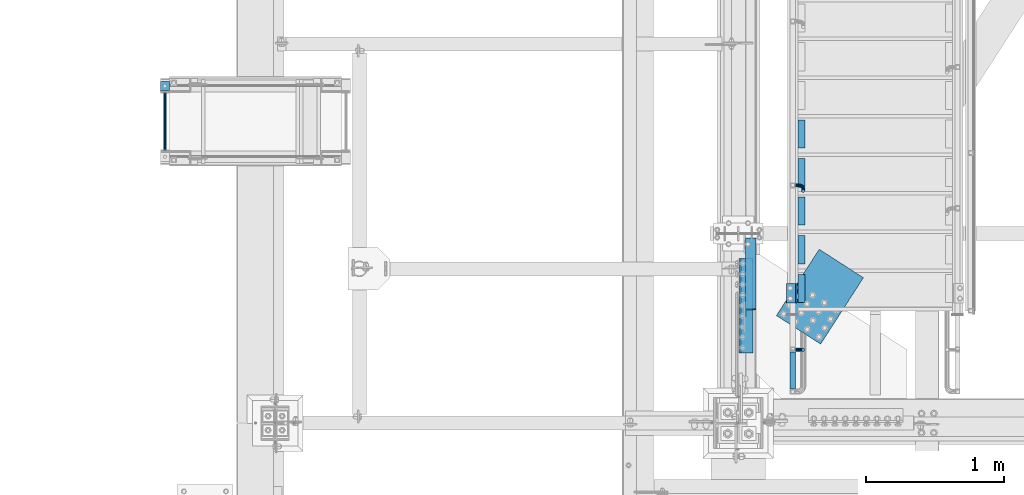
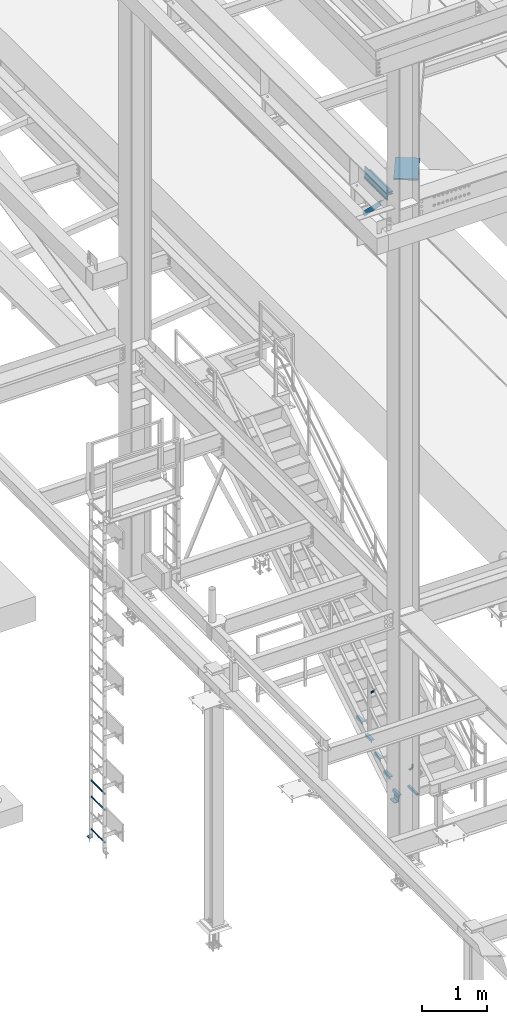
# One storey, part 2014 of 3843: 16 beams, 1 member, 6 elements without a shape of their own.
"""IFC2X3 building model written with IfcOpenShell, lengths in millimetres."""

from ifc_helpers import new_model, si_unit, frame, origin_with_axes, place, context, subcontext, project, spatial, faceted_brep, material, type_object, element, aggregate, save


model = new_model("IFC2X3")

# Units and contexts
model_context = context("Model", 3, precision=1e-05, world=origin_with_axes())
body_context = subcontext(model_context, "Body", "Model", "MODEL_VIEW")
ifc_project = project(units=[si_unit("LENGTHUNIT", "METRE", prefix="MILLI"), si_unit("AREAUNIT", "SQUARE_METRE"), si_unit("VOLUMEUNIT", "CUBIC_METRE"), si_unit("MASSUNIT", "GRAM", prefix="KILO"), si_unit("TIMEUNIT", "SECOND"), si_unit("PLANEANGLEUNIT", "RADIAN"), si_unit("SOLIDANGLEUNIT", "STERADIAN"), si_unit("THERMODYNAMICTEMPERATUREUNIT", "DEGREE_CELSIUS"), si_unit("LUMINOUSINTENSITYUNIT", "LUMEN")], contexts=[model_context])

# Site, building, storey
site_placement = place(None, origin_with_axes())
site = spatial("IfcSite", under=ifc_project, at=site_placement, CompositionType="ELEMENT")
building_placement = place(site_placement, origin_with_axes())
building = spatial("IfcBuilding", under=site, at=building_placement, Name="Undefined", CompositionType="ELEMENT")
storey_placement = place(building_placement, origin_with_axes())
storey = spatial("IfcBuildingStorey", under=building, at=storey_placement, Name="Undefined", CompositionType="ELEMENT", Elevation=0.0)

# Assembly, beam
assembly_1_placement = place(storey_placement, origin_with_axes())
assembly_1 = element("IfcElementAssembly", 1, at=assembly_1_placement, inside=storey, Name="LADDER", AssemblyPlace="NOTDEFINED", PredefinedType="RIGID_FRAME")
ifc_material_1 = material(Name="STEEL/A572-50")
beam_type_1 = type_object("IfcBeamType", Name="L3X3X3/8", PredefinedType="NOTDEFINED")
beam_1_placement = place(assembly_1_placement, frame((32394.0233459473, 28051.1249999999, 30518.1), z_axis=(0.0, 1.0, 0.0), x_axis=(1.0, 0.0, 0.0)))
beam_1 = element("IfcBeam", 2, at=beam_1_placement, type_object=beam_type_1, material=ifc_material_1, Name="ANGLE", ObjectType="L3X3X3/8", context=body_context, shape_type="Brep", body=[
    faceted_brep([(0.0, 38.0999999999985, -38.0999999999985), (0.0, 38.0999999999985, 38.0999999999985), (63.5, 38.0999999999985, 38.0999999999985), (63.5, 38.0999999999985, -38.0999999999985), (0.0, 28.5750000000007, 38.0999999999985), (63.5, 28.5750000000007, 38.0999999999985), (0.0, 28.5750000000007, -28.5750000000007), (63.5, 28.5750000000007, -28.5750000000007), (0.0, -38.0999999999985, -28.5750000000007), (63.5, -38.0999999999985, -28.5750000000007), (0.0, -38.0999999999985, -38.0999999999985), (63.5, -38.0999999999985, -38.0999999999985)], [[[0, 1, 2, 3]], [[1, 4, 5, 2]], [[4, 6, 7, 5]], [[6, 8, 9, 7]], [[8, 10, 11, 9]], [[10, 0, 3, 11]], [[5, 7, 9, 11, 3, 2]], [[10, 8, 6, 4, 1, 0]]]),
])

assembly_2_placement = place(storey_placement, origin_with_axes())
assembly_2 = element("IfcElementAssembly", 3, at=assembly_2_placement, inside=storey, Name="STAIR", AssemblyPlace="NOTDEFINED", PredefinedType="RIGID_FRAME")
beam_2_placement = place(assembly_2_placement, frame((36961.7625, 26485.85, 30518.1), z_axis=(-1.0, 0.0, 0.0), x_axis=(0.0, 1.0, 0.0)))
beam_2 = element("IfcBeam", 4, at=beam_2_placement, type_object=beam_type_1, material=ifc_material_1, Name="CLEAT", ObjectType="L3X3X3/8", context=body_context, shape_type="Brep", body=[
    faceted_brep([(0.0, 38.0999999999985, -38.0999999999985), (0.0, 38.0999999999985, 38.0999999999985), (139.699999999997, 38.0999999999985, 38.0999999999985), (139.699999999997, 38.0999999999985, -38.0999999999985), (0.0, 28.5750000000007, 38.0999999999985), (139.699999999997, 28.5750000000007, 38.0999999999985), (0.0, 28.5750000000007, -28.5750000000007), (139.699999999997, 28.5750000000007, -28.5750000000007), (0.0, -38.0999999999985, -28.5750000000007), (139.699999999997, -38.0999999999985, -28.5750000000007), (0.0, -38.0999999999985, -38.0999999999985), (139.699999999997, -38.0999999999985, -38.0999999999985)], [[[0, 1, 2, 3]], [[1, 4, 5, 2]], [[4, 6, 7, 5]], [[6, 8, 9, 7]], [[8, 10, 11, 9]], [[10, 0, 3, 11]], [[5, 7, 9, 11, 3, 2]], [[10, 8, 6, 4, 1, 0]]]),
])

assembly_3_placement = place(storey_placement, origin_with_axes())
assembly_3 = element("IfcElementAssembly", 5, at=assembly_3_placement, inside=storey, Name="RAIL", AssemblyPlace="NOTDEFINED", PredefinedType="RIGID_FRAME")
ifc_material_2 = material()
beam_type_2 = type_object("IfcBeamType", Name="HSS1-1/2X1-1/2X1/4", PredefinedType="NOTDEFINED")
beam_3_placement = place(assembly_3_placement, frame((36969.6999999524, 25844.5, 31013.4), z_axis=(0.0, 0.0, 1.0), x_axis=(0.0, 1.0, 0.0)))
beam_3 = element("IfcBeam", 6, at=beam_3_placement, type_object=beam_type_2, material=ifc_material_2, Name="RAIL", ObjectType="HSS1-1/2X1-1/2X1/4", context=body_context, shape_type="Brep", body=[
    faceted_brep([(285.750000765285, -19.0499992350015, 19.0499992350015), (285.750000765285, -19.0499992350015, -19.0499992350015), (285.750000765285, 19.0499992350015, -19.0499992350015), (285.750000765285, 19.0499992350015, 19.0499992350015), (285.750000765009, -12.6999993300014, 12.6999993299978), (285.750000765009, 12.6999993300014, 12.6999993299978), (285.750000765009, 12.6999993300014, -12.6999993299978), (285.750000765009, -12.6999993300014, -12.6999993299978), (19.0499992350015, 19.0499992350015, -19.0499992350015), (19.0499992350015, 19.0499992350015, 19.0499992350015), (19.0499992350015, -19.0499992350015, 19.0499992350015), (19.0499992350015, -19.0499992350015, -19.0499992350015), (19.0499992350015, 12.6999993299978, 12.6999993299978), (19.0499992350015, -12.6999993299978, 12.6999993299978), (19.0499992350015, -12.6999993299978, -12.6999993299978), (19.0499992350015, 12.6999993299978, -12.6999993299978)], [[[0, 1, 2, 3], [4, 5, 6, 7]], [[8, 9, 3, 2]], [[9, 10, 0, 3]], [[10, 11, 1, 0]], [[11, 8, 2, 1]], [[11, 10, 9, 8], [12, 13, 14, 15]], [[14, 13, 4, 7]], [[15, 14, 7, 6]], [[12, 15, 6, 5]], [[13, 12, 5, 4]]]),
])

# Beam
ifc_material_3 = material(Name="STEEL/A36")
beam_type_3 = type_object("IfcBeamType", Name="L2X2X3/16", PredefinedType="NOTDEFINED")
beam_4_placement = place(assembly_2_placement, frame((37033.1999999894, 27607.7169176272, 31271.4821428628), z_axis=(1.0, 0.0, 0.0), x_axis=(0.0, 1.0, 0.0)))
beam_4 = element("IfcBeam", 7, at=beam_4_placement, type_object=beam_type_3, material=ifc_material_3, Name="ANGLE", ObjectType="L2X2X3/16", context=body_context, shape_type="Brep", body=[
    faceted_brep([(0.0, 25.4000000000015, -25.4000000000015), (0.0, 25.4000000000015, 25.4000000000015), (203.199999999997, 25.4000000000015, 25.4000000000015), (203.199999999997, 25.4000000000015, -25.4000000000015), (0.0, 20.6375000000007, 25.4000000000015), (203.199999999997, 20.6375000000007, 25.4000000000015), (0.0, 20.6375000000007, -20.6375000000007), (203.199999999997, 20.6375000000007, -20.6375000000007), (0.0, -25.4000000000015, -20.6375000000007), (203.199999999997, -25.4000000000015, -20.6375000000007), (0.0, -25.4000000000015, -25.4000000000015), (203.199999999997, -25.4000000000015, -25.4000000000015)], [[[0, 1, 2, 3]], [[1, 4, 5, 2]], [[4, 6, 7, 5]], [[6, 8, 9, 7]], [[8, 10, 11, 9]], [[10, 0, 3, 11]], [[5, 7, 9, 11, 3, 2]], [[10, 8, 6, 4, 1, 0]]]),
])

beam_5_placement = place(assembly_2_placement, frame((37033.1999999894, 27328.3169176272, 31097.3107142914), z_axis=(1.0, 0.0, 0.0), x_axis=(0.0, 1.0, 0.0)))
beam_5 = element("IfcBeam", 8, at=beam_5_placement, type_object=beam_type_3, material=ifc_material_3, Name="ANGLE", ObjectType="L2X2X3/16", context=body_context, shape_type="Brep", body=[
    faceted_brep([(0.0, 25.4000000000015, -25.4000000000015), (0.0, 25.4000000000015, 25.4000000000015), (203.199999999997, 25.4000000000015, 25.4000000000015), (203.199999999997, 25.4000000000015, -25.4000000000015), (0.0, 20.6375000000007, 25.4000000000015), (203.199999999997, 20.6375000000007, 25.4000000000015), (0.0, 20.6375000000007, -20.6375000000007), (203.199999999997, 20.6375000000007, -20.6375000000007), (0.0, -25.4000000000015, -20.6375000000007), (203.199999999997, -25.4000000000015, -20.6375000000007), (0.0, -25.4000000000015, -25.4000000000015), (203.199999999997, -25.4000000000015, -25.4000000000015)], [[[0, 1, 2, 3]], [[1, 4, 5, 2]], [[4, 6, 7, 5]], [[6, 8, 9, 7]], [[8, 10, 11, 9]], [[10, 0, 3, 11]], [[5, 7, 9, 11, 3, 2]], [[10, 8, 6, 4, 1, 0]]]),
])

beam_6_placement = place(assembly_2_placement, frame((37033.1999999894, 27048.9169176272, 30923.13928572), z_axis=(1.0, 0.0, 0.0), x_axis=(0.0, 1.0, 0.0)))
beam_6 = element("IfcBeam", 9, at=beam_6_placement, type_object=beam_type_3, material=ifc_material_3, Name="ANGLE", ObjectType="L2X2X3/16", context=body_context, shape_type="Brep", body=[
    faceted_brep([(0.0, 25.4000000000015, -25.4000000000015), (0.0, 25.4000000000015, 25.4000000000015), (203.199999999997, 25.4000000000015, 25.4000000000015), (203.199999999997, 25.4000000000015, -25.4000000000015), (0.0, 20.6375000000007, 25.4000000000015), (203.199999999997, 20.6375000000007, 25.4000000000015), (0.0, 20.6375000000007, -20.6375000000007), (203.199999999997, 20.6375000000007, -20.6375000000007), (0.0, -25.4000000000015, -20.6375000000007), (203.199999999997, -25.4000000000015, -20.6375000000007), (0.0, -25.4000000000015, -25.4000000000015), (203.199999999997, -25.4000000000015, -25.4000000000015)], [[[0, 1, 2, 3]], [[1, 4, 5, 2]], [[4, 6, 7, 5]], [[6, 8, 9, 7]], [[8, 10, 11, 9]], [[10, 0, 3, 11]], [[5, 7, 9, 11, 3, 2]], [[10, 8, 6, 4, 1, 0]]]),
])

beam_7_placement = place(assembly_2_placement, frame((37033.1999999894, 26769.5169176272, 30748.9678571485), z_axis=(1.0, 0.0, 0.0), x_axis=(0.0, 1.0, 0.0)))
beam_7 = element("IfcBeam", 10, at=beam_7_placement, type_object=beam_type_3, material=ifc_material_3, Name="ANGLE", ObjectType="L2X2X3/16", context=body_context, shape_type="Brep", body=[
    faceted_brep([(0.0, 25.4000000000015, -25.4000000000015), (0.0, 25.4000000000015, 25.4000000000015), (203.199999999997, 25.4000000000015, 25.4000000000015), (203.199999999997, 25.4000000000015, -25.4000000000015), (0.0, 20.6375000000007, 25.4000000000015), (203.199999999997, 20.6375000000007, 25.4000000000015), (0.0, 20.6375000000007, -20.6375000000007), (203.199999999997, 20.6375000000007, -20.6375000000007), (0.0, -25.4000000000015, -20.6375000000007), (203.199999999997, -25.4000000000015, -20.6375000000007), (0.0, -25.4000000000015, -25.4000000000015), (203.199999999997, -25.4000000000015, -25.4000000000015)], [[[0, 1, 2, 3]], [[1, 4, 5, 2]], [[4, 6, 7, 5]], [[6, 8, 9, 7]], [[8, 10, 11, 9]], [[10, 0, 3, 11]], [[5, 7, 9, 11, 3, 2]], [[10, 8, 6, 4, 1, 0]]]),
])

beam_8_placement = place(assembly_2_placement, frame((37033.1999999894, 26490.1169176272, 30574.7964285771), z_axis=(1.0, 0.0, 0.0), x_axis=(0.0, 1.0, 0.0)))
beam_8 = element("IfcBeam", 11, at=beam_8_placement, type_object=beam_type_3, material=ifc_material_3, Name="ANGLE", ObjectType="L2X2X3/16", context=body_context, shape_type="Brep", body=[
    faceted_brep([(0.0, 25.4000000000015, -25.4000000000015), (0.0, 25.4000000000015, 25.4000000000015), (203.199999999997, 25.4000000000015, 25.4000000000015), (203.199999999997, 25.4000000000015, -25.4000000000015), (0.0, 20.6375000000007, 25.4000000000015), (203.199999999997, 20.6375000000007, 25.4000000000015), (0.0, 20.6375000000007, -20.6375000000007), (203.199999999997, 20.6375000000007, -20.6375000000007), (0.0, -25.4000000000015, -20.6375000000007), (203.199999999997, -25.4000000000015, -20.6375000000007), (0.0, -25.4000000000015, -25.4000000000015), (203.199999999997, -25.4000000000015, -25.4000000000015)], [[[0, 1, 2, 3]], [[1, 4, 5, 2]], [[4, 6, 7, 5]], [[6, 8, 9, 7]], [[8, 10, 11, 9]], [[10, 0, 3, 11]], [[5, 7, 9, 11, 3, 2]], [[10, 8, 6, 4, 1, 0]]]),
])

aggregate(assembly_2, [beam_2, beam_4, beam_5, beam_6, beam_7, beam_8])

beam_type_4 = type_object("IfcBeamType", PredefinedType="NOTDEFINED")
beam_9_placement = place(assembly_1_placement, frame((32425.7733459473, 28009.8499999999, 30659.5155151367), z_axis=(1.0, 0.0, 0.0), x_axis=(0.0, -1.0, 0.0)))
beam_9 = element("IfcBeam", 12, at=beam_9_placement, type_object=beam_type_4, material=ifc_material_1, Name="RUNG", context=body_context, shape_type="Brep", body=[
    faceted_brep([(0.0, -9.52500000000146, 0.0), (0.0, -6.73519209080405, -6.73519209079677), (419.100000000006, -6.73519209080405, -6.73519209079677), (419.100000000006, -9.52500000000146, 0.0), (2.95075507493764e-12, 2.91322521661641e-12, -9.52499961853027), (419.100000000006, 0.0, -9.52499999999418), (0.0, 6.73519209080405, -6.73519209079677), (419.100000000006, 6.73519209080405, -6.73519209079677), (0.0, 9.52500000000146, 0.0), (419.100000000006, 9.52500000000146, 0.0), (0.0, 6.73519209080405, 6.73519209079677), (419.100000000006, 6.73519209080405, 6.73519209079677), (-9.87109982941227e-13, 2.91322521661641e-12, 9.52499961853027), (419.100000000006, 0.0, 9.52499999999418), (0.0, -6.73519209080405, 6.73519209079677), (419.100000000006, -6.73519209080405, 6.73519209079677)], [[[0, 1, 2, 3]], [[1, 4, 5, 2]], [[4, 6, 7, 5]], [[6, 8, 9, 7]], [[8, 10, 11, 9]], [[10, 12, 13, 11]], [[12, 14, 15, 13]], [[14, 0, 3, 15]], [[5, 7, 9, 11, 13, 15, 3, 2]], [[14, 12, 10, 8, 6, 4, 1, 0]]]),
])

beam_10_placement = place(assembly_1_placement, frame((32425.7733459473, 28009.8499999999, 31269.1155151367), z_axis=(1.0, 0.0, 0.0), x_axis=(0.0, -1.0, 0.0)))
beam_10 = element("IfcBeam", 13, at=beam_10_placement, type_object=beam_type_4, material=ifc_material_1, Name="RUNG", context=body_context, shape_type="Brep", body=[
    faceted_brep([(0.0, -9.52500000000146, 0.0), (0.0, -6.73519209080405, -6.73519209079677), (419.100000000006, -6.73519209080405, -6.73519209079677), (419.100000000006, -9.52500000000146, 0.0), (2.95075507493764e-12, 2.91322521661641e-12, -9.52499961853027), (419.100000000006, 0.0, -9.52499999999418), (0.0, 6.73519209080405, -6.73519209079677), (419.100000000006, 6.73519209080405, -6.73519209079677), (0.0, 9.52500000000146, 0.0), (419.100000000006, 9.52500000000146, 0.0), (0.0, 6.73519209080405, 6.73519209079677), (419.100000000006, 6.73519209080405, 6.73519209079677), (-9.87109982941227e-13, 2.91322521661641e-12, 9.52499961853027), (419.100000000006, 0.0, 9.52499999999418), (0.0, -6.73519209080405, 6.73519209079677), (419.100000000006, -6.73519209080405, 6.73519209079677)], [[[0, 1, 2, 3]], [[1, 4, 5, 2]], [[4, 6, 7, 5]], [[6, 8, 9, 7]], [[8, 10, 11, 9]], [[10, 12, 13, 11]], [[12, 14, 15, 13]], [[14, 0, 3, 15]], [[5, 7, 9, 11, 13, 15, 3, 2]], [[14, 12, 10, 8, 6, 4, 1, 0]]]),
])

beam_11_placement = place(assembly_1_placement, frame((32425.7733459473, 28009.8499999999, 31573.9155151367), z_axis=(1.0, 0.0, 0.0), x_axis=(0.0, -1.0, 0.0)))
beam_11 = element("IfcBeam", 14, at=beam_11_placement, type_object=beam_type_4, material=ifc_material_1, Name="RUNG", context=body_context, shape_type="Brep", body=[
    faceted_brep([(0.0, -9.52500000000146, 0.0), (0.0, -6.73519209080405, -6.73519209079677), (419.100000000006, -6.73519209080405, -6.73519209079677), (419.100000000006, -9.52500000000146, 0.0), (2.95075507493764e-12, 2.91322521661641e-12, -9.52499961853027), (419.100000000006, 0.0, -9.52499999999418), (0.0, 6.73519209080405, -6.73519209079677), (419.100000000006, 6.73519209080405, -6.73519209079677), (0.0, 9.52500000000146, 0.0), (419.100000000006, 9.52500000000146, 0.0), (0.0, 6.73519209080405, 6.73519209079677), (419.100000000006, 6.73519209080405, 6.73519209079677), (-9.87109982941227e-13, 2.91322521661641e-12, 9.52499961853027), (419.100000000006, 0.0, 9.52499999999418), (0.0, -6.73519209080405, 6.73519209079677), (419.100000000006, -6.73519209080405, 6.73519209079677)], [[[0, 1, 2, 3]], [[1, 4, 5, 2]], [[4, 6, 7, 5]], [[6, 8, 9, 7]], [[8, 10, 11, 9]], [[10, 12, 13, 11]], [[12, 14, 15, 13]], [[14, 0, 3, 15]], [[5, 7, 9, 11, 13, 15, 3, 2]], [[14, 12, 10, 8, 6, 4, 1, 0]]]),
])

aggregate(assembly_1, [beam_1, beam_9, beam_10, beam_11])

beam_type_5 = type_object("IfcBeamType", PredefinedType="NOTDEFINED")
beam_12_placement = place(assembly_3_placement, frame((36988.7499999524, 27336.7073356212, 32022.3605124995), z_axis=(0.0, -0.848616882600525, -0.529007926750977), x_axis=(1.0, 0.0, 0.0)))
beam_12 = element("IfcBeam", 15, at=beam_12_placement, type_object=beam_type_5, material=ifc_material_3, Name="BRACKET ARM", context=body_context, shape_type="Brep", body=[
    faceted_brep([(0.0, -12.6999999999971, 0.0), (0.0, -10.9985226280696, -6.34999999999854), (19.0500015258731, -10.9985226280623, -6.34999999999854), (19.0500015258731, -12.6999999999971, -6.33008312433958e-10), (0.0, -6.35000000000582, -10.9985226280623), (19.0500015258731, -6.34999999999854, -10.9985226280623), (0.0, 0.0, -12.6999999999971), (19.0500015258731, 0.0, -12.6999999999971), (0.0, 6.35000000000582, -10.9985226280623), (19.0500015258731, 6.34999999999854, -10.9985226280623), (0.0, 10.9985226280696, -6.34999999999854), (19.0500015258731, 10.9985226280623, -6.34999999999854), (0.0, 12.6999999999971, 0.0), (19.0500015258731, 12.6999999999971, 0.0), (0.0, 10.9985226280696, 6.34999999999854), (19.0500015258731, 10.9985226280623, 6.34999999999854), (0.0, 6.35000000000582, 10.9985226280623), (19.0500015258731, 6.34999999999854, 10.9985226280623), (0.0, 0.0, 12.6999999999971), (19.0500015258731, 0.0, 12.6999999999971), (0.0, -6.35000000000582, 10.9985226280623), (19.0500015258731, -6.34999999999854, 10.9985226280623), (0.0, -10.9985226280696, 6.34999999999854), (19.0500015258731, -10.9985226280623, 6.34999999999854), (38.4903193060891, -8.8330803677236, -3.34694050252438e-10), (37.8391921052389, -7.26112024908798, 6.34999999974389), (36.0602795104642, -2.96644533684594, 10.9985226280041), (33.6302397149266, 2.90018969451194, 12.7000000002226), (31.2001999194181, 8.76682472604443, 10.9985226285644), (29.4212873247307, 13.061499638774, 6.35000000070431), (28.7701601240115, 14.6334597580644, 7.78527464717627e-10), (29.4212873248762, 13.0614996394288, -6.34999999929278), (31.2001999196509, 8.76682472718676, -10.9985226275603), (33.6302397151885, 2.90018969582889, -12.6999999997788), (36.0602795106824, -2.96644533571089, -10.9985226281206), (37.8391921053699, -7.26112024843314, -6.35000000026048), (53.7678987435793, 3.38210125690239, -6.3499999994383), (54.9710249311902, 2.17897506880399, 5.0931703299284e-10), (50.4808968708676, 6.66910312997061, -10.9985226273784), (45.9907688103704, 11.1592311906061, -12.6999999991458), (41.5006407498004, 15.6493592510378, -10.9985226270364), (38.213638876914, 18.9363611235749, -6.34999999884167), (37.0105126890558, 20.1394873109457, 1.20053300634027e-09), (38.2136388766667, 18.9363611228473, 6.35000000115542), (41.5006407493784, 15.6493592497718, 10.9985226290883), (45.9907688098756, 11.1592311891436, 12.7000000008557), (50.4808968704456, 6.66910312870459, 10.9985226287463), (53.7678987433319, 3.38210125617479, 6.35000000055879), (64.4111202489148, 19.3108078951118, -6.34999999821594), (65.9830803677178, 18.6596806939051, 1.77533365786076e-09), (60.1164453365491, 21.0897204901557, -10.9985226262725), (54.2498103051475, 23.5197602857806, -12.6999999981927), (48.3831752736587, 25.9498000811873, -10.9985226262434), (44.0885003610601, 27.7287126756128, -6.34999999817228), (42.516540241937, 28.3798398759754, 1.83354131877422e-09), (44.08850036074, 27.7287126747688, 6.35000000183209), (48.3831752731057, 25.9498000797321, 10.9985226298813), (54.2498103045073, 23.5197602840999, 12.7000000018088), (60.1164453359961, 21.0897204886933, 10.9985226298522), (64.4111202485947, 19.3108078942678, 6.35000000178115), (68.1485226282239, 38.0999984746086, -6.3499999967753), (69.8499999999913, 38.0999984741211, 2.92493496090174e-09), (63.500000000291, 38.0999984749651, -10.9985226249628), (57.1500000003434, 38.0999984750961, -12.6999999970722), (50.8000000002939, 38.0999984749651, -10.998522625312), (46.1514773720992, 38.0999984746086, -6.34999999737192), (44.4499999999971, 38.0999984741211, 2.58296495303512e-09), (46.1514773717645, 38.0999984736336, 6.35000000262517), (50.7999999996973, 38.0999984732771, 10.9985226308127), (57.1499999996449, 38.0999984731461, 12.700000002922), (63.4999999996944, 38.0999984732771, 10.9985226311619), (68.1485226278892, 38.0999984736336, 6.35000000322179), (68.1485226280638, 76.2000000002372, -6.34999999414867), (69.8499999999913, 76.199999999757, 5.84986992180347e-09), (63.5, 76.200000000601, -10.9985226222125), (57.1499999999942, 76.2000000007247, -12.6999999941472), (50.7999999999884, 76.200000000601, -10.9985226222125), (46.1514773719246, 76.2000000002372, -6.34999999414867), (44.4499999999971, 76.199999999757, 5.84986992180347e-09), (46.1514773719246, 76.1999999992695, 6.35000000584841), (50.7999999999884, 76.1999999989057, 10.9985226339122), (57.1499999999942, 76.199999998782, 12.700000005847), (63.5, 76.1999999989057, 10.9985226339122), (68.1485226280638, 76.1999999992695, 6.35000000584841)], [[[0, 1, 2, 3]], [[1, 4, 5, 2]], [[4, 6, 7, 5]], [[6, 8, 9, 7]], [[8, 10, 11, 9]], [[10, 12, 13, 11]], [[12, 14, 15, 13]], [[14, 16, 17, 15]], [[16, 18, 19, 17]], [[18, 20, 21, 19]], [[20, 22, 23, 21]], [[22, 0, 3, 23]], [[22, 20, 18, 16, 14, 12, 10, 8, 6, 4, 1, 0]], [[23, 3, 24, 25]], [[21, 23, 25, 26]], [[19, 21, 26, 27]], [[17, 19, 27, 28]], [[15, 17, 28, 29]], [[13, 15, 29, 30]], [[11, 13, 30, 31]], [[9, 11, 31, 32]], [[7, 9, 32, 33]], [[5, 7, 33, 34]], [[2, 5, 34, 35]], [[3, 2, 35, 24]], [[35, 36, 37, 24]], [[34, 38, 36, 35]], [[33, 39, 38, 34]], [[32, 40, 39, 33]], [[31, 41, 40, 32]], [[30, 42, 41, 31]], [[29, 43, 42, 30]], [[28, 44, 43, 29]], [[27, 45, 44, 28]], [[26, 46, 45, 27]], [[25, 47, 46, 26]], [[24, 37, 47, 25]], [[36, 48, 49, 37]], [[38, 50, 48, 36]], [[39, 51, 50, 38]], [[40, 52, 51, 39]], [[41, 53, 52, 40]], [[42, 54, 53, 41]], [[43, 55, 54, 42]], [[44, 56, 55, 43]], [[45, 57, 56, 44]], [[46, 58, 57, 45]], [[47, 59, 58, 46]], [[37, 49, 59, 47]], [[48, 60, 61, 49]], [[50, 62, 60, 48]], [[51, 63, 62, 50]], [[52, 64, 63, 51]], [[53, 65, 64, 52]], [[54, 66, 65, 53]], [[55, 67, 66, 54]], [[56, 68, 67, 55]], [[57, 69, 68, 56]], [[58, 70, 69, 57]], [[59, 71, 70, 58]], [[49, 61, 71, 59]], [[61, 60, 72, 73]], [[60, 62, 74, 72]], [[62, 63, 75, 74]], [[63, 64, 76, 75]], [[64, 65, 77, 76]], [[65, 66, 78, 77]], [[66, 67, 79, 78]], [[67, 68, 80, 79]], [[68, 69, 81, 80]], [[69, 70, 82, 81]], [[70, 71, 83, 82]], [[71, 61, 73, 83]], [[74, 75, 76, 77, 78, 79, 80, 81, 82, 83, 73, 72]]]),
])

beam_13_placement = place(assembly_3_placement, frame((36988.7499999524, 26147.7125003629, 31299.15), z_axis=(0.0, -1.0, 0.0), x_axis=(1.0, 0.0, 0.0)))
beam_13 = element("IfcBeam", 16, at=beam_13_placement, type_object=beam_type_5, material=ifc_material_3, Name="BRACKET ARM", context=body_context, shape_type="Brep", body=[
    faceted_brep([(0.0, -12.6999999999971, 0.0), (0.0, -10.9985226280696, -6.34999999999854), (19.0500015258731, -10.9985226280623, -6.34999999999854), (19.0500015258731, -12.6999999999971, -6.33008312433958e-10), (0.0, -6.35000000000582, -10.9985226280623), (19.0500015258731, -6.34999999999854, -10.9985226280623), (0.0, 0.0, -12.6999999999971), (19.0500015258731, 0.0, -12.6999999999971), (0.0, 6.35000000000582, -10.9985226280623), (19.0500015258731, 6.34999999999854, -10.9985226280623), (0.0, 10.9985226280696, -6.34999999999854), (19.0500015258731, 10.9985226280623, -6.34999999999854), (0.0, 12.6999999999971, 0.0), (19.0500015258731, 12.6999999999971, 0.0), (0.0, 10.9985226280696, 6.34999999999854), (19.0500015258731, 10.9985226280623, 6.34999999999854), (0.0, 6.35000000000582, 10.9985226280623), (19.0500015258731, 6.34999999999854, 10.9985226280623), (0.0, 0.0, 12.6999999999971), (19.0500015258731, 0.0, 12.6999999999971), (0.0, -6.35000000000582, 10.9985226280623), (19.0500015258731, -6.34999999999854, 10.9985226280623), (0.0, -10.9985226280696, 6.34999999999854), (19.0500015258731, -10.9985226280623, 6.34999999999854), (38.4903193060891, -8.8330803677236, -3.34694050252438e-10), (37.8391921052389, -7.26112024908798, 6.34999999974389), (36.0602795104642, -2.96644533684594, 10.9985226280041), (33.6302397149266, 2.90018969451194, 12.7000000002226), (31.2001999194181, 8.76682472604443, 10.9985226285644), (29.4212873247307, 13.061499638774, 6.35000000070431), (28.7701601240115, 14.6334597580644, 7.78527464717627e-10), (29.4212873248762, 13.0614996394288, -6.34999999929278), (31.2001999196509, 8.76682472718676, -10.9985226275603), (33.6302397151885, 2.90018969582889, -12.6999999997788), (36.0602795106824, -2.96644533571089, -10.9985226281206), (37.8391921053699, -7.26112024843314, -6.35000000026048), (53.7678987435793, 3.38210125690239, -6.3499999994383), (54.9710249311902, 2.17897506880399, 5.0931703299284e-10), (50.4808968708676, 6.66910312997061, -10.9985226273784), (45.9907688103704, 11.1592311906061, -12.6999999991458), (41.5006407498004, 15.6493592510378, -10.9985226270364), (38.213638876914, 18.9363611235749, -6.34999999884167), (37.0105126890558, 20.1394873109457, 1.20053300634027e-09), (38.2136388766667, 18.9363611228473, 6.35000000115542), (41.5006407493784, 15.6493592497718, 10.9985226290883), (45.9907688098756, 11.1592311891436, 12.7000000008557), (50.4808968704456, 6.66910312870459, 10.9985226287463), (53.7678987433319, 3.38210125617479, 6.35000000055879), (64.4111202489148, 19.3108078951118, -6.34999999821594), (65.9830803677178, 18.6596806939051, 1.77533365786076e-09), (60.1164453365491, 21.0897204901557, -10.9985226262725), (54.2498103051475, 23.5197602857806, -12.6999999981927), (48.3831752736587, 25.9498000811873, -10.9985226262434), (44.0885003610601, 27.7287126756128, -6.34999999817228), (42.516540241937, 28.3798398759754, 1.83354131877422e-09), (44.08850036074, 27.7287126747688, 6.35000000183209), (48.3831752731057, 25.9498000797321, 10.9985226298813), (54.2498103045073, 23.5197602840999, 12.7000000018088), (60.1164453359961, 21.0897204886933, 10.9985226298522), (64.4111202485947, 19.3108078942678, 6.35000000178115), (68.1485226282239, 38.0999984746086, -6.3499999967753), (69.8499999999913, 38.0999984741211, 2.92493496090174e-09), (63.500000000291, 38.0999984749651, -10.9985226249628), (57.1500000003434, 38.0999984750961, -12.6999999970722), (50.8000000002939, 38.0999984749651, -10.998522625312), (46.1514773720992, 38.0999984746086, -6.34999999737192), (44.4499999999971, 38.0999984741211, 2.58296495303512e-09), (46.1514773717645, 38.0999984736336, 6.35000000262517), (50.7999999996973, 38.0999984732771, 10.9985226308127), (57.1499999996449, 38.0999984731461, 12.700000002922), (63.4999999996944, 38.0999984732771, 10.9985226311619), (68.1485226278892, 38.0999984736336, 6.35000000322179), (68.1485226280638, 76.2000000002372, -6.34999999414867), (69.8499999999913, 76.199999999757, 5.84986992180347e-09), (63.5, 76.200000000601, -10.9985226222125), (57.1499999999942, 76.2000000007247, -12.6999999941472), (50.7999999999884, 76.200000000601, -10.9985226222125), (46.1514773719246, 76.2000000002372, -6.34999999414867), (44.4499999999971, 76.199999999757, 5.84986992180347e-09), (46.1514773719246, 76.1999999992695, 6.35000000584841), (50.7999999999884, 76.1999999989057, 10.9985226339122), (57.1499999999942, 76.199999998782, 12.700000005847), (63.5, 76.1999999989057, 10.9985226339122), (68.1485226280638, 76.1999999992695, 6.35000000584841)], [[[0, 1, 2, 3]], [[1, 4, 5, 2]], [[4, 6, 7, 5]], [[6, 8, 9, 7]], [[8, 10, 11, 9]], [[10, 12, 13, 11]], [[12, 14, 15, 13]], [[14, 16, 17, 15]], [[16, 18, 19, 17]], [[18, 20, 21, 19]], [[20, 22, 23, 21]], [[22, 0, 3, 23]], [[22, 20, 18, 16, 14, 12, 10, 8, 6, 4, 1, 0]], [[23, 3, 24, 25]], [[21, 23, 25, 26]], [[19, 21, 26, 27]], [[17, 19, 27, 28]], [[15, 17, 28, 29]], [[13, 15, 29, 30]], [[11, 13, 30, 31]], [[9, 11, 31, 32]], [[7, 9, 32, 33]], [[5, 7, 33, 34]], [[2, 5, 34, 35]], [[3, 2, 35, 24]], [[35, 36, 37, 24]], [[34, 38, 36, 35]], [[33, 39, 38, 34]], [[32, 40, 39, 33]], [[31, 41, 40, 32]], [[30, 42, 41, 31]], [[29, 43, 42, 30]], [[28, 44, 43, 29]], [[27, 45, 44, 28]], [[26, 46, 45, 27]], [[25, 47, 46, 26]], [[24, 37, 47, 25]], [[36, 48, 49, 37]], [[38, 50, 48, 36]], [[39, 51, 50, 38]], [[40, 52, 51, 39]], [[41, 53, 52, 40]], [[42, 54, 53, 41]], [[43, 55, 54, 42]], [[44, 56, 55, 43]], [[45, 57, 56, 44]], [[46, 58, 57, 45]], [[47, 59, 58, 46]], [[37, 49, 59, 47]], [[48, 60, 61, 49]], [[50, 62, 60, 48]], [[51, 63, 62, 50]], [[52, 64, 63, 51]], [[53, 65, 64, 52]], [[54, 66, 65, 53]], [[55, 67, 66, 54]], [[56, 68, 67, 55]], [[57, 69, 68, 56]], [[58, 70, 69, 57]], [[59, 71, 70, 58]], [[49, 61, 71, 59]], [[61, 60, 72, 73]], [[60, 62, 74, 72]], [[62, 63, 75, 74]], [[63, 64, 76, 75]], [[64, 65, 77, 76]], [[65, 66, 78, 77]], [[66, 67, 79, 78]], [[67, 68, 80, 79]], [[68, 69, 81, 80]], [[69, 70, 82, 81]], [[70, 71, 83, 82]], [[71, 61, 73, 83]], [[74, 75, 76, 77, 78, 79, 80, 81, 82, 83, 73, 72]]]),
])

aggregate(assembly_3, [beam_12, beam_13, beam_3])

# Assembly, beams
assembly_4_placement = place(storey_placement, origin_with_axes())
assembly_4 = element("IfcElementAssembly", 17, at=assembly_4_placement, inside=storey, Name="PLATE", AssemblyPlace="NOTDEFINED", PredefinedType="RIGID_FRAME")
beam_type_6 = type_object("IfcBeamType", Name="L4X4X1/2", PredefinedType="NOTDEFINED")
beam_14_placement = place(assembly_4_placement, frame((36633.150000007, 26809.6999999996, 42297.35), z_axis=(1.0, 0.0, 0.0), x_axis=(0.0, -1.0, 0.0)))
beam_14 = element("IfcBeam", 18, at=beam_14_placement, type_object=beam_type_6, material=ifc_material_1, Name="ANGLE", ObjectType="L4X4X1/2", context=body_context, shape_type="Brep", body=[
    faceted_brep([(0.0, 50.8000000000029, -50.8000000000029), (0.0, 50.8000000000029, 50.8000000000029), (685.800000000003, 50.8000000000029, 50.8000000000029), (685.800000000003, 50.8000000000029, -50.8000000000029), (0.0, 38.0999999999985, 50.8000000000029), (685.800000000003, 38.0999999999985, 50.8000000000029), (0.0, 38.0999999999985, -38.0999999999985), (685.800000000003, 38.0999999999985, -38.1000000000058), (0.0, -50.8000000000029, -38.1000000000058), (685.800000000003, -50.8000000000029, -38.1000000000058), (0.0, -50.8000000000029, -50.8000000000029), (685.800000000003, -50.8000000000029, -50.8000000000029)], [[[0, 1, 2, 3]], [[1, 4, 5, 2]], [[4, 6, 7, 5]], [[6, 8, 9, 7]], [[8, 10, 11, 9]], [[10, 0, 3, 11]], [[5, 7, 9, 11, 3, 2]], [[10, 8, 6, 4, 1, 0]]]),
])
beam_15_placement = place(assembly_4_placement, frame((36633.150000002, 26123.8999999996, 42167.175), z_axis=(1.0, 0.0, 0.0), x_axis=(0.0, 1.0, 0.0)))
beam_15 = element("IfcBeam", 19, at=beam_15_placement, type_object=beam_type_6, material=ifc_material_1, Name="ANGLE", ObjectType="L4X4X1/2", context=body_context, shape_type="Brep", body=[
    faceted_brep([(0.0, 50.8000000000029, -50.8000000000029), (0.0, 50.8000000000029, 50.8000000000029), (685.800000000003, 50.8000000000029, 50.8000000000029), (685.800000000003, 50.8000000000029, -50.8000000000029), (0.0, 38.0999999999985, 50.8000000000029), (685.800000000003, 38.0999999999985, 50.8000000000029), (0.0, 38.0999999999985, -38.0999999999985), (685.800000000003, 38.0999999999985, -38.1000000000058), (0.0, -50.8000000000029, -38.1000000000058), (685.800000000003, -50.8000000000029, -38.1000000000058), (0.0, -50.8000000000029, -50.8000000000029), (685.800000000003, -50.8000000000029, -50.8000000000029)], [[[0, 1, 2, 3]], [[1, 4, 5, 2]], [[4, 6, 7, 5]], [[6, 8, 9, 7]], [[8, 10, 11, 9]], [[10, 0, 3, 11]], [[5, 7, 9, 11, 3, 2]], [[10, 8, 6, 4, 1, 0]]]),
])
aggregate(assembly_4, [beam_14, beam_15])

# Assembly, member
assembly_5_placement = place(storey_placement, origin_with_axes())
assembly_5 = element("IfcElementAssembly", 20, at=assembly_5_placement, inside=storey, Name="ANGLE", AssemblyPlace="NOTDEFINED", PredefinedType="RIGID_FRAME")
member_type = type_object("IfcMemberType", Name="L3X3X1/4", PredefinedType="NOTDEFINED")
member_placement = place(assembly_5_placement, frame((36664.9, 26987.5, 41300.4), z_axis=(0.0, -0.707106781186548, -0.707106781186548), x_axis=(0.0, -0.707106781186682, 0.707106781186413)))
member = element("IfcMember", 21, at=member_placement, type_object=member_type, material=ifc_material_1, Name="ANGLE", ObjectType="L3X3X1/4", context=body_context, shape_type="Brep", body=[
    faceted_brep([(83.0012806675732, 38.0999999999985, -38.0999999999058), (83.0012806675732, -38.0999999999985, -38.0999999999058), (83.0012806675804, -38.0999999999985, -31.7499999999254), (83.0012806675804, 31.75, -31.7499999999254), (83.0012806675804, 31.75, 38.0999999999058), (83.0012806675804, 38.0999999999985, 38.0999999999058), (810.534203444928, 31.75, 38.0999999999112), (810.534203444928, 38.0999999999985, 38.0999999999112), (810.534203444538, 38.0999999999985, -38.099999999904), (810.534203444538, -38.0999999999985, -38.099999999904), (810.534203444575, -38.0999999999985, -31.7499999999272), (810.534203444575, 31.75, -31.7499999999272)], [[[0, 1, 2, 3, 4, 5]], [[5, 4, 6, 7]], [[0, 5, 7, 8]], [[1, 0, 8, 9]], [[2, 1, 9, 10]], [[3, 2, 10, 11]], [[4, 3, 11, 6]], [[10, 9, 8, 7, 6, 11]]]),
])
aggregate(assembly_5, [member])

# Assembly, beam
assembly_6_placement = place(storey_placement, origin_with_axes())
assembly_6 = element("IfcElementAssembly", 22, at=assembly_6_placement, inside=storey, AssemblyPlace="NOTDEFINED", PredefinedType="RIGID_FRAME")
beam_type_7 = type_object("IfcBeamType", PredefinedType="NOTDEFINED")
beam_16_placement = place(assembly_6_placement, frame((37011.8595542289, 26291.5865825289, 42259.25), z_axis=(0.840334760005035, -0.542067792003252, 0.0), x_axis=(0.542067792003244, 0.84033476000504, 0.0)))
beam_16 = element("IfcBeam", 23, at=beam_16_placement, type_object=beam_type_7, material=ifc_material_1, Name="PLATE", context=body_context, shape_type="Brep", body=[
    faceted_brep([(5.85714587941766e-10, 12.6999999999971, -190.500000000349), (-6.14818418398499e-10, 12.6999999999971, 190.500000000364), (571.499999996191, 12.6999999999971, 190.49999999936), (571.499999997392, 12.6999999999971, -190.500000001353), (-6.14818418398499e-10, -12.6999999999971, 190.500000000364), (571.499999996191, -12.6999999999971, 190.49999999936), (5.85714587941766e-10, -12.6999999999971, -190.500000000349), (571.499999997392, -12.6999999999971, -190.500000001353)], [[[0, 1, 2, 3]], [[1, 4, 5, 2]], [[4, 6, 7, 5]], [[6, 0, 3, 7]], [[5, 7, 3, 2]], [[6, 4, 1, 0]]]),
])
aggregate(assembly_6, [beam_16])

save(model, "model.ifc")
